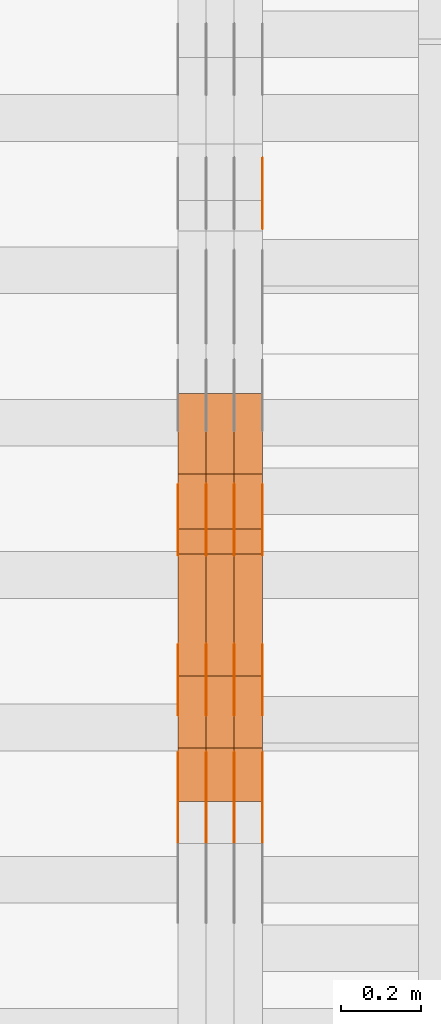
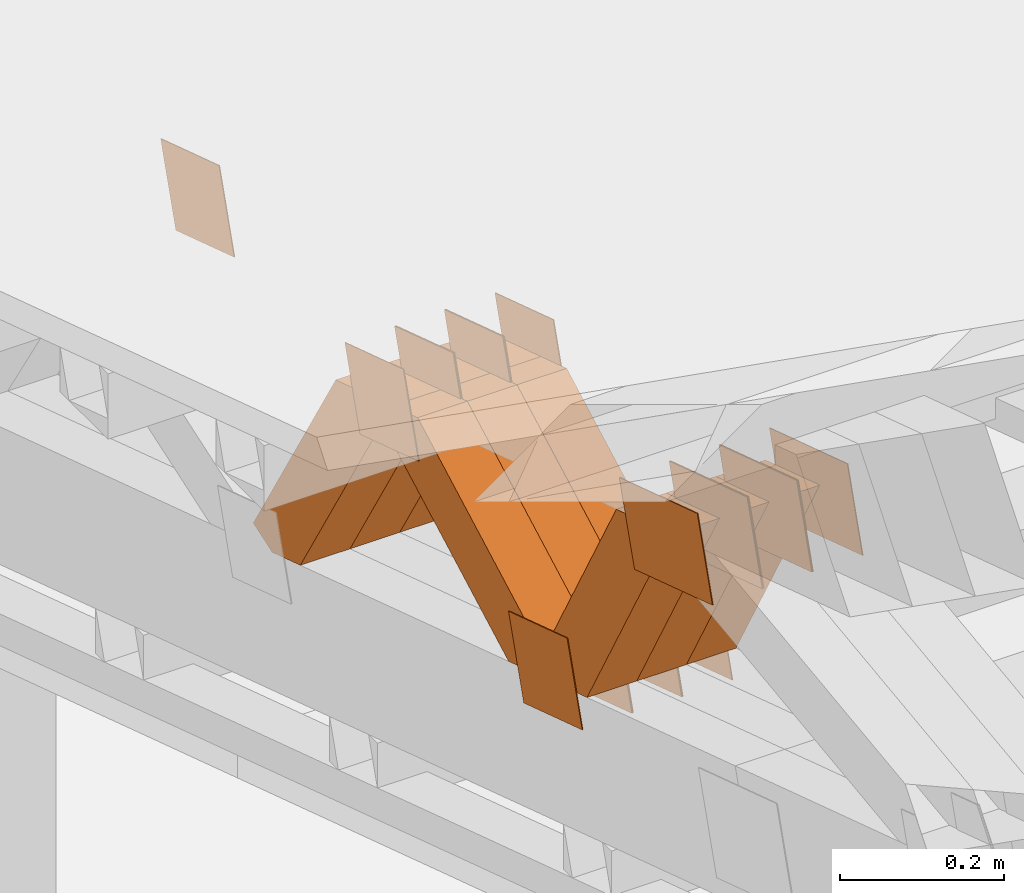
# One storey, part 170 of 385: 28 proxies.
"""IFC2X3 building model written with IfcOpenShell, lengths in millimetres."""

from ifc_helpers import new_model, entity, si_unit, converted_unit, derived_unit, direction, frame, origin, place, context, subcontext, project, spatial, polyline, outline, extrude, source, transform, mapped, material, type_object, type_shapes, element, save


model = new_model("IFC2X3")

# Units and contexts
model_context = context("Model", 3, precision=0.01, world=origin(), true_north=direction((6.12303176911189e-17, 1.0)))
body_context = subcontext(model_context, "Body", "Model", "MODEL_VIEW")
ifc_project = project(units=[si_unit("LENGTHUNIT", "METRE", prefix="MILLI"), si_unit("AREAUNIT", "SQUARE_METRE"), si_unit("VOLUMEUNIT", "CUBIC_METRE"), converted_unit("PLANEANGLEUNIT", "DEGREE", entity("IfcRatioMeasure", 0.0174532925199433), si_unit("PLANEANGLEUNIT", "RADIAN"), dimensions=[0, 0, 0, 0, 0, 0, 0]), si_unit("MASSUNIT", "GRAM", prefix="KILO"), derived_unit("MASSDENSITYUNIT", [(si_unit("MASSUNIT", "GRAM", prefix="KILO"), 1), (si_unit("LENGTHUNIT", "METRE"), -3)]), si_unit("TIMEUNIT", "SECOND"), si_unit("FREQUENCYUNIT", "HERTZ"), si_unit("THERMODYNAMICTEMPERATUREUNIT", "DEGREE_CELSIUS"), derived_unit("THERMALTRANSMITTANCEUNIT", [(si_unit("MASSUNIT", "GRAM", prefix="KILO"), 1), (si_unit("THERMODYNAMICTEMPERATUREUNIT", "KELVIN"), -1), (si_unit("TIMEUNIT", "SECOND"), -3)]), derived_unit("VOLUMETRICFLOWRATEUNIT", [(si_unit("LENGTHUNIT", "METRE"), 3), (si_unit("TIMEUNIT", "SECOND"), -1)]), si_unit("ELECTRICCURRENTUNIT", "AMPERE"), si_unit("ELECTRICVOLTAGEUNIT", "VOLT"), si_unit("POWERUNIT", "WATT"), si_unit("FORCEUNIT", "NEWTON", prefix="KILO"), si_unit("ILLUMINANCEUNIT", "LUX"), si_unit("LUMINOUSFLUXUNIT", "LUMEN"), si_unit("LUMINOUSINTENSITYUNIT", "CANDELA"), derived_unit("USERDEFINED", [(si_unit("MASSUNIT", "GRAM", prefix="KILO"), -1), (si_unit("LENGTHUNIT", "METRE"), -2), (si_unit("TIMEUNIT", "SECOND"), 3), (si_unit("LUMINOUSFLUXUNIT", "LUMEN"), 1)]), derived_unit("LINEARVELOCITYUNIT", [(si_unit("LENGTHUNIT", "METRE"), 1), (si_unit("TIMEUNIT", "SECOND"), -1)]), si_unit("PRESSUREUNIT", "PASCAL"), derived_unit("USERDEFINED", [(si_unit("LENGTHUNIT", "METRE"), -2), (si_unit("MASSUNIT", "GRAM", prefix="KILO"), 1), (si_unit("TIMEUNIT", "SECOND"), -2)])], contexts=[model_context])

# Site, building, storey
site_placement = place(None, origin())
site = spatial("IfcSite", under=ifc_project, at=site_placement, CompositionType="ELEMENT")
building_placement = place(site_placement, origin())
building = spatial("IfcBuilding", under=site, at=building_placement, CompositionType="ELEMENT")
storey_placement = place(building_placement, origin())
storey = spatial("IfcBuildingStorey", under=building, at=storey_placement, Name="Default", CompositionType="ELEMENT", Elevation=0.0)

# Proxies
ifc_material_1 = material(Name="IfcSurfaceStyle #40058")
building_element_proxy_type_1 = type_object("IfcBuildingElementProxyType", PredefinedType="NOTDEFINED", material=ifc_material_1)
shared_shape_1 = source(origin(), body_context, "Body", "SweptSolid", [
    extrude(outline(polyline([(-74.9998605591059, -59.9999264677526), (74.999875428623, -59.9999264677526), (74.9998605591068, 59.9999264677526), (-74.9998754286239, 59.9999264677526), (-74.9998605591059, -59.9999264677526)])), frame((75.0000889884782, 60.0000460315623, 0.0), z_axis=(0.0, 0.0, 1.0), x_axis=(-1.0, 0.0, 0.0)), (0.0, 0.0, 1.0), 1.3),
])
type_shapes(building_element_proxy_type_1, [shared_shape_1])
proxy_1_placement = place(building_placement, frame((386.299999999986, 20621.9679769682, 2241.76551219004), z_axis=(-1.0, 0.0, 0.0), x_axis=(0.0, -0.951056516295154, 0.309016994374948)))
element("IfcBuildingElementProxy", 1, at=proxy_1_placement, inside=storey, type_object=building_element_proxy_type_1, material=ifc_material_1, context=body_context, shape_type="MappedRepresentation", body=[
    mapped(shared_shape_1, transform((0.0, 0.0, 0.0), scale=1.0)),
])
ifc_material_2 = material(Name="IfcSurfaceStyle #38690")
building_element_proxy_type_2 = type_object("IfcBuildingElementProxyType", PredefinedType="NOTDEFINED", material=ifc_material_2)
shared_shape_2 = source(origin(), body_context, "Body", "SweptSolid", [
    extrude(outline(polyline([(-74.9998982809088, -60.000042563519), (74.9998377068237, -60.000042563519), (74.9998982809079, 60.0000425635189), (-74.9998377068227, 60.0000425635189), (-74.9998982809088, -60.000042563519)])), frame((75.0001050385304, 60.0001177331169, 0.0), z_axis=(0.0, 0.0, 1.0), x_axis=(-1.0, 0.0, 0.0)), (0.0, 0.0, 1.0), 1.3),
])
type_shapes(building_element_proxy_type_2, [shared_shape_2])
proxy_2_placement = place(building_placement, frame((386.299999999986, 19806.7306653882, 2506.65203571776), z_axis=(-1.0, 0.0, 0.0), x_axis=(0.0, -0.951056516295154, 0.309016994374948)))
element("IfcBuildingElementProxy", 2, at=proxy_2_placement, inside=storey, type_object=building_element_proxy_type_2, material=ifc_material_2, context=body_context, shape_type="MappedRepresentation", body=[
    mapped(shared_shape_2, transform((0.0, 0.0, 0.0), scale=1.0)),
])
ifc_material_3 = material(Name="IfcSurfaceStyle #38633")
building_element_proxy_type_3 = type_object("IfcBuildingElementProxyType", PredefinedType="NOTDEFINED", material=ifc_material_3)
shared_shape_3 = source(origin(), body_context, "Body", "SweptSolid", [
    extrude(outline(polyline([(-74.9998982809088, -60.000042563519), (74.9998377068237, -60.000042563519), (74.9998982809079, 60.0000425635189), (-74.9998377068227, 60.0000425635189), (-74.9998982809088, -60.000042563519)])), frame((75.0001050385304, 60.0001177331169, 0.0), z_axis=(0.0, 0.0, 1.0), x_axis=(-1.0, 0.0, 0.0)), (0.0, 0.0, 1.0), 1.3),
])
type_shapes(building_element_proxy_type_3, [shared_shape_3])
proxy_3_placement = place(building_placement, frame((315.0, 19806.7306653882, 2506.65203571776), z_axis=(-1.0, 0.0, 0.0), x_axis=(0.0, -0.951056516295154, 0.309016994374948)))
element("IfcBuildingElementProxy", 3, at=proxy_3_placement, inside=storey, type_object=building_element_proxy_type_3, material=ifc_material_3, context=body_context, shape_type="MappedRepresentation", body=[
    mapped(shared_shape_3, transform((0.0, 0.0, 0.0), scale=1.0)),
])
ifc_material_4 = material(Name="IfcSurfaceStyle #38576")
building_element_proxy_type_4 = type_object("IfcBuildingElementProxyType", PredefinedType="NOTDEFINED", material=ifc_material_4)
shared_shape_4 = source(origin(), body_context, "Body", "SweptSolid", [
    extrude(outline(polyline([(-74.9998982809088, -60.000042563519), (74.9998377068237, -60.000042563519), (74.9998982809079, 60.0000425635189), (-74.9998377068227, 60.0000425635189), (-74.9998982809088, -60.000042563519)])), frame((75.0001050385304, 60.0001177331169, 0.0), z_axis=(0.0, 0.0, 1.0), x_axis=(-1.0, 0.0, 0.0)), (0.0, 0.0, 1.0), 1.3),
])
type_shapes(building_element_proxy_type_4, [shared_shape_4])
proxy_4_placement = place(building_placement, frame((316.299999999986, 19806.7306653882, 2506.65203571776), z_axis=(-1.0, 0.0, 0.0), x_axis=(0.0, -0.951056516295154, 0.309016994374948)))
element("IfcBuildingElementProxy", 4, at=proxy_4_placement, inside=storey, type_object=building_element_proxy_type_4, material=ifc_material_4, context=body_context, shape_type="MappedRepresentation", body=[
    mapped(shared_shape_4, transform((0.0, 0.0, 0.0), scale=1.0)),
])
ifc_material_5 = material(Name="IfcSurfaceStyle #38519")
building_element_proxy_type_5 = type_object("IfcBuildingElementProxyType", PredefinedType="NOTDEFINED", material=ifc_material_5)
shared_shape_5 = source(origin(), body_context, "Body", "SweptSolid", [
    extrude(outline(polyline([(-74.9998982809088, -60.000042563519), (74.9998377068237, -60.000042563519), (74.9998982809079, 60.0000425635189), (-74.9998377068227, 60.0000425635189), (-74.9998982809088, -60.000042563519)])), frame((75.0001050385304, 60.0001177331169, 0.0), z_axis=(0.0, 0.0, 1.0), x_axis=(-1.0, 0.0, 0.0)), (0.0, 0.0, 1.0), 1.29999999999999),
])
type_shapes(building_element_proxy_type_5, [shared_shape_5])
proxy_5_placement = place(building_placement, frame((245.0, 19806.7306653882, 2506.65203571776), z_axis=(-1.0, 0.0, 0.0), x_axis=(0.0, -0.951056516295154, 0.309016994374948)))
element("IfcBuildingElementProxy", 5, at=proxy_5_placement, inside=storey, type_object=building_element_proxy_type_5, material=ifc_material_5, context=body_context, shape_type="MappedRepresentation", body=[
    mapped(shared_shape_5, transform((0.0, 0.0, 0.0), scale=1.0)),
])
ifc_material_6 = material(Name="IfcSurfaceStyle #38462")
building_element_proxy_type_6 = type_object("IfcBuildingElementProxyType", PredefinedType="NOTDEFINED", material=ifc_material_6)
shared_shape_6 = source(origin(), body_context, "Body", "SweptSolid", [
    extrude(outline(polyline([(-74.9998982809088, -60.000042563519), (74.9998377068237, -60.000042563519), (74.9998982809079, 60.0000425635189), (-74.9998377068227, 60.0000425635189), (-74.9998982809088, -60.000042563519)])), frame((75.0001050385304, 60.0001177331169, 0.0), z_axis=(0.0, 0.0, 1.0), x_axis=(-1.0, 0.0, 0.0)), (0.0, 0.0, 1.0), 1.29999999999999),
])
type_shapes(building_element_proxy_type_6, [shared_shape_6])
proxy_6_placement = place(building_placement, frame((246.299999999986, 19806.7306653882, 2506.65203571776), z_axis=(-1.0, 0.0, 0.0), x_axis=(0.0, -0.951056516295154, 0.309016994374948)))
element("IfcBuildingElementProxy", 6, at=proxy_6_placement, inside=storey, type_object=building_element_proxy_type_6, material=ifc_material_6, context=body_context, shape_type="MappedRepresentation", body=[
    mapped(shared_shape_6, transform((0.0, 0.0, 0.0), scale=1.0)),
])
ifc_material_7 = material(Name="IfcSurfaceStyle #38405")
building_element_proxy_type_7 = type_object("IfcBuildingElementProxyType", PredefinedType="NOTDEFINED", material=ifc_material_7)
shared_shape_7 = source(origin(), body_context, "Body", "SweptSolid", [
    extrude(outline(polyline([(-74.9998982809088, -60.000042563519), (74.9998377068237, -60.000042563519), (74.9998982809079, 60.0000425635189), (-74.9998377068227, 60.0000425635189), (-74.9998982809088, -60.000042563519)])), frame((75.0001050385304, 60.0001177331169, 0.0), z_axis=(0.0, 0.0, 1.0), x_axis=(-1.0, 0.0, 0.0)), (0.0, 0.0, 1.0), 1.29999999999999),
])
type_shapes(building_element_proxy_type_7, [shared_shape_7])
proxy_7_placement = place(building_placement, frame((175.0, 19806.7306653882, 2506.65203571776), z_axis=(-1.0, 0.0, 0.0), x_axis=(0.0, -0.951056516295154, 0.309016994374948)))
element("IfcBuildingElementProxy", 7, at=proxy_7_placement, inside=storey, type_object=building_element_proxy_type_7, material=ifc_material_7, context=body_context, shape_type="MappedRepresentation", body=[
    mapped(shared_shape_7, transform((0.0, 0.0, 0.0), scale=1.0)),
])
ifc_material_8 = material(Name="IfcSurfaceStyle #37322")
building_element_proxy_type_8 = type_object("IfcBuildingElementProxyType", PredefinedType="NOTDEFINED", material=ifc_material_8)
shared_shape_8 = source(origin(), body_context, "Body", "SweptSolid", [
    extrude(outline(polyline([(-99.9998479918963, -59.9999913366637), (99.9998251396114, -59.9999913366637), (99.9998102700952, 59.9999913366637), (-99.9997874178102, 59.9999913366637), (-99.9998479918963, -59.9999913366637)])), frame((99.9998251396114, 60.0000609537942, 0.0), z_axis=(0.0, 0.0, 1.0), x_axis=(-1.0, 0.0, 0.0)), (0.0, 0.0, 1.0), 1.3),
])
type_shapes(building_element_proxy_type_8, [shared_shape_8])
proxy_8_placement = place(building_placement, frame((386.299999999986, 19136.9072023289, 2711.67346128215), z_axis=(-1.0, 0.0, 0.0), x_axis=(0.0, -0.951056516295154, 0.309016994374948)))
element("IfcBuildingElementProxy", 8, at=proxy_8_placement, inside=storey, type_object=building_element_proxy_type_8, material=ifc_material_8, context=body_context, shape_type="MappedRepresentation", body=[
    mapped(shared_shape_8, transform((0.0, 0.0, 0.0), scale=1.0)),
])
ifc_material_9 = material(Name="IfcSurfaceStyle #37265")
building_element_proxy_type_9 = type_object("IfcBuildingElementProxyType", PredefinedType="NOTDEFINED", material=ifc_material_9)
shared_shape_9 = source(origin(), body_context, "Body", "SweptSolid", [
    extrude(outline(polyline([(-99.9998479918963, -59.9999913366637), (99.9998251396114, -59.9999913366637), (99.9998102700952, 59.9999913366637), (-99.9997874178102, 59.9999913366637), (-99.9998479918963, -59.9999913366637)])), frame((99.9998251396114, 60.0000609537942, 0.0), z_axis=(0.0, 0.0, 1.0), x_axis=(-1.0, 0.0, 0.0)), (0.0, 0.0, 1.0), 1.3),
])
type_shapes(building_element_proxy_type_9, [shared_shape_9])
proxy_9_placement = place(building_placement, frame((315.0, 19136.9072023289, 2711.67346128215), z_axis=(-1.0, 0.0, 0.0), x_axis=(0.0, -0.951056516295154, 0.309016994374948)))
element("IfcBuildingElementProxy", 9, at=proxy_9_placement, inside=storey, type_object=building_element_proxy_type_9, material=ifc_material_9, context=body_context, shape_type="MappedRepresentation", body=[
    mapped(shared_shape_9, transform((0.0, 0.0, 0.0), scale=1.0)),
])
ifc_material_10 = material(Name="IfcSurfaceStyle #37208")
building_element_proxy_type_10 = type_object("IfcBuildingElementProxyType", PredefinedType="NOTDEFINED", material=ifc_material_10)
shared_shape_10 = source(origin(), body_context, "Body", "SweptSolid", [
    extrude(outline(polyline([(-99.9998479918963, -59.9999913366637), (99.9998251396114, -59.9999913366637), (99.9998102700952, 59.9999913366637), (-99.9997874178102, 59.9999913366637), (-99.9998479918963, -59.9999913366637)])), frame((99.9998251396114, 60.0000609537942, 0.0), z_axis=(0.0, 0.0, 1.0), x_axis=(-1.0, 0.0, 0.0)), (0.0, 0.0, 1.0), 1.3),
])
type_shapes(building_element_proxy_type_10, [shared_shape_10])
proxy_10_placement = place(building_placement, frame((316.299999999986, 19136.9072023289, 2711.67346128215), z_axis=(-1.0, 0.0, 0.0), x_axis=(0.0, -0.951056516295154, 0.309016994374948)))
element("IfcBuildingElementProxy", 10, at=proxy_10_placement, inside=storey, type_object=building_element_proxy_type_10, material=ifc_material_10, context=body_context, shape_type="MappedRepresentation", body=[
    mapped(shared_shape_10, transform((0.0, 0.0, 0.0), scale=1.0)),
])
ifc_material_11 = material(Name="IfcSurfaceStyle #37151")
building_element_proxy_type_11 = type_object("IfcBuildingElementProxyType", PredefinedType="NOTDEFINED", material=ifc_material_11)
shared_shape_11 = source(origin(), body_context, "Body", "SweptSolid", [
    extrude(outline(polyline([(-99.9998479918963, -59.9999913366637), (99.9998251396114, -59.9999913366637), (99.9998102700952, 59.9999913366637), (-99.9997874178102, 59.9999913366637), (-99.9998479918963, -59.9999913366637)])), frame((99.9998251396114, 60.0000609537942, 0.0), z_axis=(0.0, 0.0, 1.0), x_axis=(-1.0, 0.0, 0.0)), (0.0, 0.0, 1.0), 1.29999999999998),
])
type_shapes(building_element_proxy_type_11, [shared_shape_11])
proxy_11_placement = place(building_placement, frame((245.0, 19136.9072023289, 2711.67346128215), z_axis=(-1.0, 0.0, 0.0), x_axis=(0.0, -0.951056516295154, 0.309016994374948)))
element("IfcBuildingElementProxy", 11, at=proxy_11_placement, inside=storey, type_object=building_element_proxy_type_11, material=ifc_material_11, context=body_context, shape_type="MappedRepresentation", body=[
    mapped(shared_shape_11, transform((0.0, 0.0, 0.0), scale=1.0)),
])
ifc_material_12 = material(Name="IfcSurfaceStyle #37094")
building_element_proxy_type_12 = type_object("IfcBuildingElementProxyType", PredefinedType="NOTDEFINED", material=ifc_material_12)
shared_shape_12 = source(origin(), body_context, "Body", "SweptSolid", [
    extrude(outline(polyline([(-99.9998479918963, -59.9999913366637), (99.9998251396114, -59.9999913366637), (99.9998102700952, 59.9999913366637), (-99.9997874178102, 59.9999913366637), (-99.9998479918963, -59.9999913366637)])), frame((99.9998251396114, 60.0000609537942, 0.0), z_axis=(0.0, 0.0, 1.0), x_axis=(-1.0, 0.0, 0.0)), (0.0, 0.0, 1.0), 1.29999999999998),
])
type_shapes(building_element_proxy_type_12, [shared_shape_12])
proxy_12_placement = place(building_placement, frame((246.299999999986, 19136.9072023289, 2711.67346128215), z_axis=(-1.0, 0.0, 0.0), x_axis=(0.0, -0.951056516295154, 0.309016994374948)))
element("IfcBuildingElementProxy", 12, at=proxy_12_placement, inside=storey, type_object=building_element_proxy_type_12, material=ifc_material_12, context=body_context, shape_type="MappedRepresentation", body=[
    mapped(shared_shape_12, transform((0.0, 0.0, 0.0), scale=1.0)),
])
ifc_material_13 = material(Name="IfcSurfaceStyle #37037")
building_element_proxy_type_13 = type_object("IfcBuildingElementProxyType", PredefinedType="NOTDEFINED", material=ifc_material_13)
shared_shape_13 = source(origin(), body_context, "Body", "SweptSolid", [
    extrude(outline(polyline([(-99.9998479918963, -59.9999913366637), (99.9998251396114, -59.9999913366637), (99.9998102700952, 59.9999913366637), (-99.9997874178102, 59.9999913366637), (-99.9998479918963, -59.9999913366637)])), frame((99.9998251396114, 60.0000609537942, 0.0), z_axis=(0.0, 0.0, 1.0), x_axis=(-1.0, 0.0, 0.0)), (0.0, 0.0, 1.0), 1.29999999999999),
])
type_shapes(building_element_proxy_type_13, [shared_shape_13])
proxy_13_placement = place(building_placement, frame((175.0, 19136.9072023289, 2711.67346128215), z_axis=(-1.0, 0.0, 0.0), x_axis=(0.0, -0.951056516295154, 0.309016994374948)))
element("IfcBuildingElementProxy", 13, at=proxy_13_placement, inside=storey, type_object=building_element_proxy_type_13, material=ifc_material_13, context=body_context, shape_type="MappedRepresentation", body=[
    mapped(shared_shape_13, transform((0.0, 0.0, 0.0), scale=1.0)),
])
ifc_material_14 = material(Name="IfcSurfaceStyle #32192")
building_element_proxy_type_14 = type_object("IfcBuildingElementProxyType", PredefinedType="NOTDEFINED", material=ifc_material_14)
shared_shape_14 = source(origin(), body_context, "Body", "SweptSolid", [
    extrude(outline(polyline([(-74.9998605591127, -59.9999264677599), (74.999875428618, -59.9999264677599), (74.9998605591127, 59.9999264677599), (-74.999875428618, 59.9999264677599), (-74.9998605591127, -59.9999264677599)])), frame((75.0002655673825, 60.0000016373433, 0.0), z_axis=(0.0, 0.0, 1.0), x_axis=(-1.0, 0.0, 0.0)), (0.0, 0.0, 1.0), 1.3),
])
type_shapes(building_element_proxy_type_14, [shared_shape_14])
proxy_14_placement = place(building_placement, frame((386.299999999986, 19407.1136664358, 2348.71056820494), z_axis=(-1.0, 0.0, 0.0), x_axis=(0.0, -0.951056516295124, 0.309016994375039)))
element("IfcBuildingElementProxy", 14, at=proxy_14_placement, inside=storey, type_object=building_element_proxy_type_14, material=ifc_material_14, context=body_context, shape_type="MappedRepresentation", body=[
    mapped(shared_shape_14, transform((0.0, 0.0, 0.0), scale=1.0)),
])
ifc_material_15 = material(Name="IfcSurfaceStyle #32135")
building_element_proxy_type_15 = type_object("IfcBuildingElementProxyType", PredefinedType="NOTDEFINED", material=ifc_material_15)
shared_shape_15 = source(origin(), body_context, "Body", "SweptSolid", [
    extrude(outline(polyline([(-74.9998605591127, -59.9999264677599), (74.999875428618, -59.9999264677599), (74.9998605591127, 59.9999264677599), (-74.999875428618, 59.9999264677599), (-74.9998605591127, -59.9999264677599)])), frame((75.0002655673825, 60.0000016373433, 0.0), z_axis=(0.0, 0.0, 1.0), x_axis=(-1.0, 0.0, 0.0)), (0.0, 0.0, 1.0), 1.3),
])
type_shapes(building_element_proxy_type_15, [shared_shape_15])
proxy_15_placement = place(building_placement, frame((315.0, 19407.1136664358, 2348.71056820494), z_axis=(-1.0, 0.0, 0.0), x_axis=(0.0, -0.951056516295124, 0.309016994375039)))
element("IfcBuildingElementProxy", 15, at=proxy_15_placement, inside=storey, type_object=building_element_proxy_type_15, material=ifc_material_15, context=body_context, shape_type="MappedRepresentation", body=[
    mapped(shared_shape_15, transform((0.0, 0.0, 0.0), scale=1.0)),
])
ifc_material_16 = material(Name="IfcSurfaceStyle #32078")
building_element_proxy_type_16 = type_object("IfcBuildingElementProxyType", PredefinedType="NOTDEFINED", material=ifc_material_16)
shared_shape_16 = source(origin(), body_context, "Body", "SweptSolid", [
    extrude(outline(polyline([(-74.9998605591127, -59.9999264677599), (74.999875428618, -59.9999264677599), (74.9998605591127, 59.9999264677599), (-74.999875428618, 59.9999264677599), (-74.9998605591127, -59.9999264677599)])), frame((75.0002655673825, 60.0000016373433, 0.0), z_axis=(0.0, 0.0, 1.0), x_axis=(-1.0, 0.0, 0.0)), (0.0, 0.0, 1.0), 1.3),
])
type_shapes(building_element_proxy_type_16, [shared_shape_16])
proxy_16_placement = place(building_placement, frame((316.299999999986, 19407.1136664358, 2348.71056820494), z_axis=(-1.0, 0.0, 0.0), x_axis=(0.0, -0.951056516295124, 0.309016994375039)))
element("IfcBuildingElementProxy", 16, at=proxy_16_placement, inside=storey, type_object=building_element_proxy_type_16, material=ifc_material_16, context=body_context, shape_type="MappedRepresentation", body=[
    mapped(shared_shape_16, transform((0.0, 0.0, 0.0), scale=1.0)),
])
ifc_material_17 = material(Name="IfcSurfaceStyle #32021")
building_element_proxy_type_17 = type_object("IfcBuildingElementProxyType", PredefinedType="NOTDEFINED", material=ifc_material_17)
shared_shape_17 = source(origin(), body_context, "Body", "SweptSolid", [
    extrude(outline(polyline([(-74.9998605591127, -59.9999264677599), (74.999875428618, -59.9999264677599), (74.9998605591127, 59.9999264677599), (-74.999875428618, 59.9999264677599), (-74.9998605591127, -59.9999264677599)])), frame((75.0002655673825, 60.0000016373433, 0.0), z_axis=(0.0, 0.0, 1.0), x_axis=(-1.0, 0.0, 0.0)), (0.0, 0.0, 1.0), 1.29999999999999),
])
type_shapes(building_element_proxy_type_17, [shared_shape_17])
proxy_17_placement = place(building_placement, frame((245.0, 19407.1136664358, 2348.71056820494), z_axis=(-1.0, 0.0, 0.0), x_axis=(0.0, -0.951056516295124, 0.309016994375039)))
element("IfcBuildingElementProxy", 17, at=proxy_17_placement, inside=storey, type_object=building_element_proxy_type_17, material=ifc_material_17, context=body_context, shape_type="MappedRepresentation", body=[
    mapped(shared_shape_17, transform((0.0, 0.0, 0.0), scale=1.0)),
])
ifc_material_18 = material(Name="IfcSurfaceStyle #31964")
building_element_proxy_type_18 = type_object("IfcBuildingElementProxyType", PredefinedType="NOTDEFINED", material=ifc_material_18)
shared_shape_18 = source(origin(), body_context, "Body", "SweptSolid", [
    extrude(outline(polyline([(-74.9998605591127, -59.9999264677599), (74.999875428618, -59.9999264677599), (74.9998605591127, 59.9999264677599), (-74.999875428618, 59.9999264677599), (-74.9998605591127, -59.9999264677599)])), frame((75.0002655673825, 60.0000016373433, 0.0), z_axis=(0.0, 0.0, 1.0), x_axis=(-1.0, 0.0, 0.0)), (0.0, 0.0, 1.0), 1.29999999999999),
])
type_shapes(building_element_proxy_type_18, [shared_shape_18])
proxy_18_placement = place(building_placement, frame((246.299999999986, 19407.1136664358, 2348.71056820494), z_axis=(-1.0, 0.0, 0.0), x_axis=(0.0, -0.951056516295124, 0.309016994375039)))
element("IfcBuildingElementProxy", 18, at=proxy_18_placement, inside=storey, type_object=building_element_proxy_type_18, material=ifc_material_18, context=body_context, shape_type="MappedRepresentation", body=[
    mapped(shared_shape_18, transform((0.0, 0.0, 0.0), scale=1.0)),
])
ifc_material_19 = material(Name="IfcSurfaceStyle #31907")
building_element_proxy_type_19 = type_object("IfcBuildingElementProxyType", PredefinedType="NOTDEFINED", material=ifc_material_19)
shared_shape_19 = source(origin(), body_context, "Body", "SweptSolid", [
    extrude(outline(polyline([(-74.9998605591127, -59.9999264677599), (74.999875428618, -59.9999264677599), (74.9998605591127, 59.9999264677599), (-74.999875428618, 59.9999264677599), (-74.9998605591127, -59.9999264677599)])), frame((75.0002655673825, 60.0000016373433, 0.0), z_axis=(0.0, 0.0, 1.0), x_axis=(-1.0, 0.0, 0.0)), (0.0, 0.0, 1.0), 1.29999999999999),
])
type_shapes(building_element_proxy_type_19, [shared_shape_19])
proxy_19_placement = place(building_placement, frame((175.0, 19407.1136664358, 2348.71056820494), z_axis=(-1.0, 0.0, 0.0), x_axis=(0.0, -0.951056516295124, 0.309016994375039)))
element("IfcBuildingElementProxy", 19, at=proxy_19_placement, inside=storey, type_object=building_element_proxy_type_19, material=ifc_material_19, context=body_context, shape_type="MappedRepresentation", body=[
    mapped(shared_shape_19, transform((0.0, 0.0, 0.0), scale=1.0)),
])
ifc_material_20 = material(Name="IfcSurfaceStyle #15434")
building_element_proxy_type_20 = type_object("IfcBuildingElementProxyType", Name="T1-W40 15432", PredefinedType="NOTDEFINED", material=ifc_material_20)
shared_shape_20 = source(origin(), body_context, "Body", "SweptSolid", [
    extrude(outline(polyline([(-190.697067347251, -47.4992767218045), (178.704677543904, -47.4992767218045), (178.119540532346, -0.000296092407564622), (126.935785980356, 47.4999913795318), (-293.062936709355, 47.4988581564849), (-190.697067347251, -47.4992767218045)])), frame((178.7049897723, 47.4999913795318, 0.0), z_axis=(0.0, 0.0, 1.0), x_axis=(-1.0, 0.0, 0.0)), (0.0, 0.0, 1.0), 70.0),
])
type_shapes(building_element_proxy_type_20, [shared_shape_20])
proxy_20_placement = place(building_placement, frame((385.0, 19280.269490882, 2403.36730959494), z_axis=(-1.0, 0.0, 0.0), x_axis=(0.0, -0.48691092455798, 0.873451630913866)))
element("IfcBuildingElementProxy", 20, at=proxy_20_placement, inside=storey, type_object=building_element_proxy_type_20, material=ifc_material_20, Name="T1-W40", context=body_context, shape_type="MappedRepresentation", body=[
    mapped(shared_shape_20, transform((0.0, 0.0, 0.0), scale=1.0)),
])
ifc_material_21 = material(Name="IfcSurfaceStyle #15368")
building_element_proxy_type_21 = type_object("IfcBuildingElementProxyType", Name="T1-W40 15366", PredefinedType="NOTDEFINED", material=ifc_material_21)
shared_shape_21 = source(origin(), body_context, "Body", "SweptSolid", [
    extrude(outline(polyline([(-190.697067347251, -47.4992767218045), (178.704677543904, -47.4992767218045), (178.119540532346, -0.000296092407564622), (126.935785980356, 47.4999913795318), (-293.062936709355, 47.4988581564849), (-190.697067347251, -47.4992767218045)])), frame((178.7049897723, 47.4999913795318, 0.0), z_axis=(0.0, 0.0, 1.0), x_axis=(-1.0, 0.0, 0.0)), (0.0, 0.0, 1.0), 70.0),
])
type_shapes(building_element_proxy_type_21, [shared_shape_21])
proxy_21_placement = place(building_placement, frame((315.0, 19280.269490882, 2403.36730959494), z_axis=(-1.0, 0.0, 0.0), x_axis=(0.0, -0.48691092455798, 0.873451630913866)))
element("IfcBuildingElementProxy", 21, at=proxy_21_placement, inside=storey, type_object=building_element_proxy_type_21, material=ifc_material_21, Name="T1-W40", context=body_context, shape_type="MappedRepresentation", body=[
    mapped(shared_shape_21, transform((0.0, 0.0, 0.0), scale=1.0)),
])
ifc_material_22 = material(Name="IfcSurfaceStyle #15302")
building_element_proxy_type_22 = type_object("IfcBuildingElementProxyType", Name="T1-W40 15300", PredefinedType="NOTDEFINED", material=ifc_material_22)
shared_shape_22 = source(origin(), body_context, "Body", "SweptSolid", [
    extrude(outline(polyline([(-190.697067347251, -47.4992767218045), (178.704677543904, -47.4992767218045), (178.119540532346, -0.000296092407564622), (126.935785980356, 47.4999913795318), (-293.062936709355, 47.4988581564849), (-190.697067347251, -47.4992767218045)])), frame((178.7049897723, 47.4999913795318, 0.0), z_axis=(0.0, 0.0, 1.0), x_axis=(-1.0, 0.0, 0.0)), (0.0, 0.0, 1.0), 70.0),
])
type_shapes(building_element_proxy_type_22, [shared_shape_22])
proxy_22_placement = place(building_placement, frame((245.0, 19280.269490882, 2403.36730959494), z_axis=(-1.0, 0.0, 0.0), x_axis=(0.0, -0.48691092455798, 0.873451630913866)))
element("IfcBuildingElementProxy", 22, at=proxy_22_placement, inside=storey, type_object=building_element_proxy_type_22, material=ifc_material_22, Name="T1-W40", context=body_context, shape_type="MappedRepresentation", body=[
    mapped(shared_shape_22, transform((0.0, 0.0, 0.0), scale=1.0)),
])
ifc_material_23 = material(Name="IfcSurfaceStyle #15038")
building_element_proxy_type_23 = type_object("IfcBuildingElementProxyType", Name="T1-W47 15036", PredefinedType="NOTDEFINED", material=ifc_material_23)
shared_shape_23 = source(origin(), body_context, "Body", "SweptSolid", [
    extrude(outline(polyline([(-273.154581805017, -47.5000119135351), (121.157675769026, -47.5000119135351), (166.341960897813, -0.000128144957132403), (168.441931699108, 47.5000759860137), (-182.78698656093, 47.5000759860137), (-273.154581805017, -47.5000119135351)])), frame((168.441931699108, 47.5000759860137, 0.0), z_axis=(0.0, 0.0, 1.0), x_axis=(-1.0, 0.0, 0.0)), (0.0, 0.0, 1.0), 70.0),
])
type_shapes(building_element_proxy_type_23, [shared_shape_23])
proxy_23_placement = place(building_placement, frame((385.0, 19755.0380859375, 2553.712890625), z_axis=(-1.0, 0.0, 0.0), x_axis=(0.0, -0.879386813332609, -0.476108005117242)))
element("IfcBuildingElementProxy", 23, at=proxy_23_placement, inside=storey, type_object=building_element_proxy_type_23, material=ifc_material_23, Name="T1-W47", context=body_context, shape_type="MappedRepresentation", body=[
    mapped(shared_shape_23, transform((0.0, 0.0, 0.0), scale=1.0)),
])
ifc_material_24 = material(Name="IfcSurfaceStyle #14972")
building_element_proxy_type_24 = type_object("IfcBuildingElementProxyType", Name="T1-W47 14970", PredefinedType="NOTDEFINED", material=ifc_material_24)
shared_shape_24 = source(origin(), body_context, "Body", "SweptSolid", [
    extrude(outline(polyline([(-273.154581805017, -47.5000119135351), (121.157675769026, -47.5000119135351), (166.341960897813, -0.000128144957132403), (168.441931699108, 47.5000759860137), (-182.78698656093, 47.5000759860137), (-273.154581805017, -47.5000119135351)])), frame((168.441931699108, 47.5000759860137, 0.0), z_axis=(0.0, 0.0, 1.0), x_axis=(-1.0, 0.0, 0.0)), (0.0, 0.0, 1.0), 70.0),
])
type_shapes(building_element_proxy_type_24, [shared_shape_24])
proxy_24_placement = place(building_placement, frame((315.0, 19755.0380859375, 2553.712890625), z_axis=(-1.0, 0.0, 0.0), x_axis=(0.0, -0.879386813332609, -0.476108005117242)))
element("IfcBuildingElementProxy", 24, at=proxy_24_placement, inside=storey, type_object=building_element_proxy_type_24, material=ifc_material_24, Name="T1-W47", context=body_context, shape_type="MappedRepresentation", body=[
    mapped(shared_shape_24, transform((0.0, 0.0, 0.0), scale=1.0)),
])
ifc_material_25 = material(Name="IfcSurfaceStyle #14906")
building_element_proxy_type_25 = type_object("IfcBuildingElementProxyType", Name="T1-W47 14904", PredefinedType="NOTDEFINED", material=ifc_material_25)
shared_shape_25 = source(origin(), body_context, "Body", "SweptSolid", [
    extrude(outline(polyline([(-273.154581805017, -47.5000119135351), (121.157675769026, -47.5000119135351), (166.341960897813, -0.000128144957132403), (168.441931699108, 47.5000759860137), (-182.78698656093, 47.5000759860137), (-273.154581805017, -47.5000119135351)])), frame((168.441931699108, 47.5000759860137, 0.0), z_axis=(0.0, 0.0, 1.0), x_axis=(-1.0, 0.0, 0.0)), (0.0, 0.0, 1.0), 70.0),
])
type_shapes(building_element_proxy_type_25, [shared_shape_25])
proxy_25_placement = place(building_placement, frame((245.0, 19755.0380859375, 2553.712890625), z_axis=(-1.0, 0.0, 0.0), x_axis=(0.0, -0.879386813332609, -0.476108005117242)))
element("IfcBuildingElementProxy", 25, at=proxy_25_placement, inside=storey, type_object=building_element_proxy_type_25, material=ifc_material_25, Name="T1-W47", context=body_context, shape_type="MappedRepresentation", body=[
    mapped(shared_shape_25, transform((0.0, 0.0, 0.0), scale=1.0)),
])
ifc_material_26 = material(Name="IfcSurfaceStyle #14642")
building_element_proxy_type_26 = type_object("IfcBuildingElementProxyType", Name="T1-W34 14640", PredefinedType="NOTDEFINED", material=ifc_material_26)
shared_shape_26 = source(origin(), body_context, "Body", "SweptSolid", [
    extrude(outline(polyline([(-197.657161937088, -47.499796538607), (193.17680883218, -47.499796538607), (182.92464491562, -1.98968224184526e-05), (128.354123102956, 47.4998064870182), (-306.798414913668, 47.4998064870182), (-197.657161937088, -47.499796538607)])), frame((193.176852028916, 47.4998566383869, 0.0), z_axis=(0.0, 0.0, 1.0), x_axis=(-1.0, 0.0, 0.0)), (0.0, 0.0, 1.0), 70.0),
])
type_shapes(building_element_proxy_type_26, [shared_shape_26])
proxy_26_placement = place(building_placement, frame((385.0, 19987.8030409043, 2165.75390635484), z_axis=(-1.0, 0.0, 0.0), x_axis=(0.0, -0.514479403471631, 0.857502736674044)))
element("IfcBuildingElementProxy", 26, at=proxy_26_placement, inside=storey, type_object=building_element_proxy_type_26, material=ifc_material_26, Name="T1-W34", context=body_context, shape_type="MappedRepresentation", body=[
    mapped(shared_shape_26, transform((0.0, 0.0, 0.0), scale=1.0)),
])
ifc_material_27 = material(Name="IfcSurfaceStyle #14576")
building_element_proxy_type_27 = type_object("IfcBuildingElementProxyType", Name="T1-W34 14574", PredefinedType="NOTDEFINED", material=ifc_material_27)
shared_shape_27 = source(origin(), body_context, "Body", "SweptSolid", [
    extrude(outline(polyline([(-197.657161937088, -47.499796538607), (193.17680883218, -47.499796538607), (182.92464491562, -1.98968224184526e-05), (128.354123102956, 47.4998064870182), (-306.798414913668, 47.4998064870182), (-197.657161937088, -47.499796538607)])), frame((193.176852028916, 47.4998566383869, 0.0), z_axis=(0.0, 0.0, 1.0), x_axis=(-1.0, 0.0, 0.0)), (0.0, 0.0, 1.0), 70.0),
])
type_shapes(building_element_proxy_type_27, [shared_shape_27])
proxy_27_placement = place(building_placement, frame((315.0, 19987.8030409043, 2165.75390635484), z_axis=(-1.0, 0.0, 0.0), x_axis=(0.0, -0.514479403471631, 0.857502736674044)))
element("IfcBuildingElementProxy", 27, at=proxy_27_placement, inside=storey, type_object=building_element_proxy_type_27, material=ifc_material_27, Name="T1-W34", context=body_context, shape_type="MappedRepresentation", body=[
    mapped(shared_shape_27, transform((0.0, 0.0, 0.0), scale=1.0)),
])
ifc_material_28 = material(Name="IfcSurfaceStyle #14510")
building_element_proxy_type_28 = type_object("IfcBuildingElementProxyType", Name="T1-W34 14508", PredefinedType="NOTDEFINED", material=ifc_material_28)
shared_shape_28 = source(origin(), body_context, "Body", "SweptSolid", [
    extrude(outline(polyline([(-197.657161937088, -47.499796538607), (193.17680883218, -47.499796538607), (182.92464491562, -1.98968224184526e-05), (128.354123102956, 47.4998064870182), (-306.798414913668, 47.4998064870182), (-197.657161937088, -47.499796538607)])), frame((193.176852028916, 47.4998566383869, 0.0), z_axis=(0.0, 0.0, 1.0), x_axis=(-1.0, 0.0, 0.0)), (0.0, 0.0, 1.0), 70.0),
])
type_shapes(building_element_proxy_type_28, [shared_shape_28])
proxy_28_placement = place(building_placement, frame((245.0, 19987.8030409043, 2165.75390635484), z_axis=(-1.0, 0.0, 0.0), x_axis=(0.0, -0.514479403471631, 0.857502736674044)))
element("IfcBuildingElementProxy", 28, at=proxy_28_placement, inside=storey, type_object=building_element_proxy_type_28, material=ifc_material_28, Name="T1-W34", context=body_context, shape_type="MappedRepresentation", body=[
    mapped(shared_shape_28, transform((0.0, 0.0, 0.0), scale=1.0)),
])

save(model, "model.ifc")
